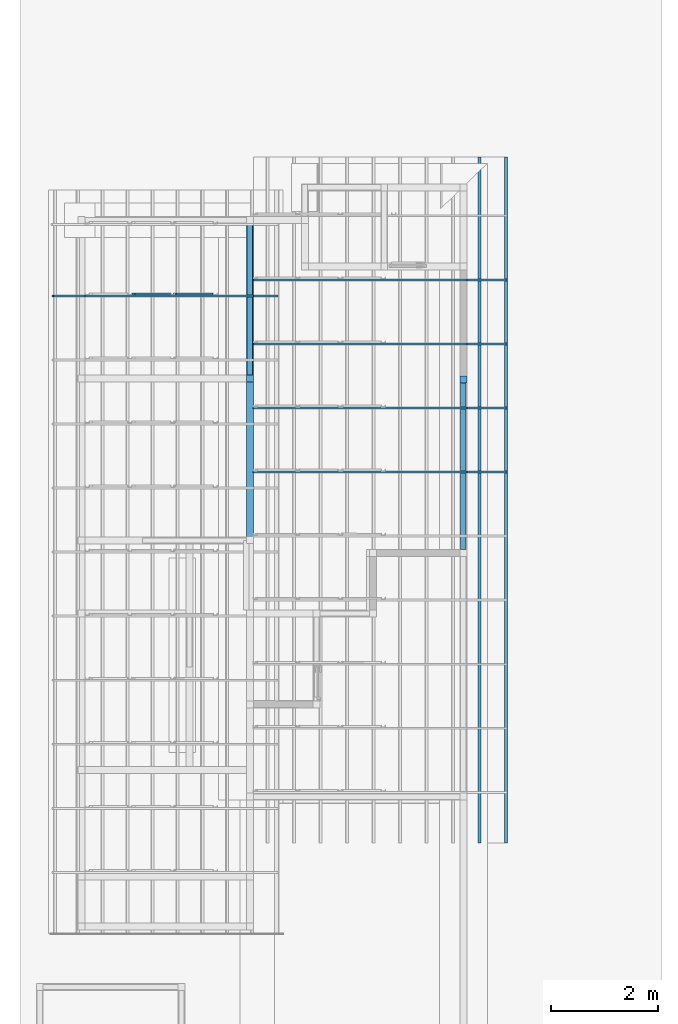
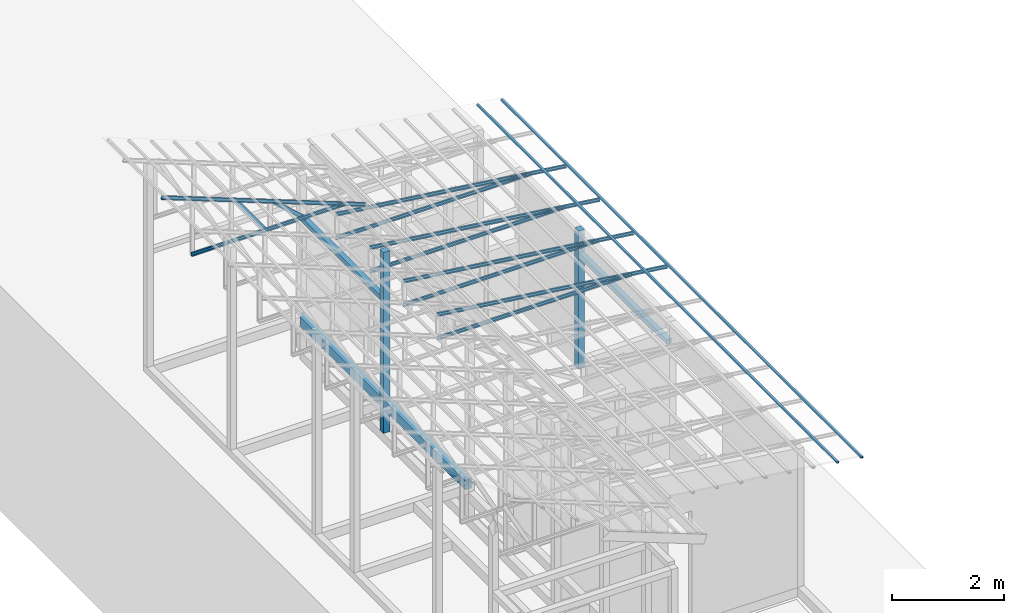
# One storey, part 13 of 22: 14 members, 5 beams, 2 elements without a shape of their own.
"""IFC4 building model written with IfcOpenShell, lengths in millimetres."""

from ifc_helpers import new_model, entity, si_unit, converted_unit, frame, origin_with_axes, origin_2d_with_axis, place, context, subcontext, project, spatial, indexed_curve, rectangle, hollow_rectangle, c_section, outline, extrude, clip, halfspace, material, material_profile, profile_set, profile_usage, type_object, element, aggregate, save


model = new_model("IFC4")

# Units and contexts
model_context = context("Model", 3, precision=1e-05, world=origin_with_axes())
plan_context = context("Plan", 2, precision=1e-05, world=origin_2d_with_axis())
body_context = subcontext(model_context, "Body", "Model", "MODEL_VIEW")
ifc_project = project(units=[si_unit("VOLUMEUNIT", "CUBIC_METRE"), si_unit("LENGTHUNIT", "METRE", prefix="MILLI"), si_unit("AREAUNIT", "SQUARE_METRE"), converted_unit("PLANEANGLEUNIT", "degree", entity("IfcReal", 0.0174532925199433), si_unit("PLANEANGLEUNIT", "RADIAN"), dimensions=[0, 0, 0, 0, 0, 0, 0])], contexts=[model_context, plan_context])

# Site, building, storey
site_placement = place(None, origin_with_axes())
site = spatial("IfcSite", under=ifc_project, at=site_placement)
building_placement = place(site_placement, origin_with_axes())
building = spatial("IfcBuilding", under=site, at=building_placement, Name="2")
storey_placement = place(building_placement, frame((0.0, 0.0, 200.000002980232), z_axis=(0.0, 0.0, 1.0), x_axis=(1.0, 0.0, 0.0)))
storey = spatial("IfcBuildingStorey", under=building, at=storey_placement)

# Beams
ifc_material_1 = material(Name="Concrete")
ifc_material_profile_1 = material_profile(ifc_material_1, outline(indexed_curve([(-65.0, 99.9999923706055), (65.0, 99.9999923706055), (65.0, -99.9999923706055), (-65.0, -99.9999923706055), (-65.0, 99.9999923706055)])))
ifc_profile_set_1 = profile_set([ifc_material_profile_1])
ifc_profile_usage_1 = profile_usage(ifc_profile_set_1, cardinal=3)
beam_type_1 = type_object("IfcBeamType", PredefinedType="BEAM", material=ifc_profile_set_1)
beam_1_placement = place(storey_placement, frame((-3934.99541282654, 11360.2285385132, 535.003766417503), z_axis=(3.89414367418746e-07, 0.999999999999875, 3.13916473260139e-07), x_axis=(-0.999999999999924, 3.89414367418765e-07, -7.40532613008271e-09)))
element("IfcBeam", 1, at=beam_1_placement, inside=storey, type_object=beam_type_1, material=ifc_profile_usage_1, Name="Beam", PredefinedType="BEAM", context=body_context, shape_type="Clipping", body=[
    clip(extrude(outline(indexed_curve([(-65.0, 99.9999923706055), (65.0, 99.9999923706055), (65.0, -99.9999923706055), (-65.0, -99.9999923706055), (-65.0, 99.9999923706055)])), frame((65.0000076293945, 100.0, 0.0), z_axis=(0.0, 0.0, 1.0), x_axis=(1.0, 0.0, 0.0)), (0.0, 0.0, 1.0), 6004.77314872396), halfspace(frame((8.64611209294708e-05, -735.00669002533, 6004.77361679077), z_axis=(0.707110941410065, -2.64117772985628e-07, 0.707102596759796), x_axis=(-3.73516739055016e-07, -0.99999999999993, 0.0)), False)),
])
ifc_material_profile_2 = material_profile(ifc_material_1, rectangle(XDim=130.000015258789, YDim=130.000015258789, kind="CURVE"))
ifc_profile_set_2 = profile_set([ifc_material_profile_2])
ifc_profile_usage_2 = profile_usage(ifc_profile_set_2, cardinal=5)
beam_type_2 = type_object("IfcBeamType", PredefinedType="BEAM", material=ifc_profile_set_2)
beam_2_placement = place(storey_placement, frame((-3999.99594688416, 14330.0046920776, 4.47034838035876e-05), z_axis=(0.0, 0.0, 1.0), x_axis=(1.0, 0.0, 0.0)))
element("IfcBeam", 2, at=beam_2_placement, inside=storey, type_object=beam_type_2, material=ifc_profile_usage_2, Name="Column", PredefinedType="BEAM", context=body_context, shape_type="SweptSolid", body=[
    extrude(rectangle(XDim=130.000015258789, YDim=130.000015258789, kind="CURVE"), origin_with_axes(), (0.0, 0.0, 1.0), 3934.94913943236),
])
ifc_profile_usage_3 = profile_usage(ifc_profile_set_2, cardinal=5)
beam_3_placement = place(storey_placement, frame((0.00166893005371094, 14314.9995803833, 0.00216066837332995), z_axis=(0.0, 0.0, 1.0), x_axis=(1.0, 0.0, 0.0)))
element("IfcBeam", 3, at=beam_3_placement, inside=storey, type_object=beam_type_2, material=ifc_profile_usage_3, Name="Column", PredefinedType="BEAM", context=body_context, shape_type="SweptSolid", body=[
    extrude(rectangle(XDim=130.000015258789, YDim=130.000015258789, kind="CURVE"), origin_with_axes(), (0.0, 0.0, 1.0), 3010.00912205527),
])

# Assembly, members
assembly_1_placement = place(storey_placement, frame((-1561.45393848419, 6600.0657081604, 3019.63977515697), z_axis=(0.0, 0.0, 1.0), x_axis=(1.0, 0.0, 0.0)))
assembly_1 = element("IfcElementAssembly", 4, at=assembly_1_placement, inside=storey, Name="K1")
ifc_material_2 = material(Name="STEEL")
ifc_material_profile_3 = material_profile(ifc_material_2, c_section(Depth=75.0, Width=35.0, WallThickness=1.0, Girth=1.0, kind="CURVE"))
ifc_profile_set_3 = profile_set([ifc_material_profile_3])
ifc_profile_usage_4 = profile_usage(ifc_profile_set_3, cardinal=9)
member_type_1 = type_object("IfcMemberType", Name="C75", PredefinedType="CHORD", material=ifc_profile_set_3)
member_1_placement = place(assembly_1_placement, frame((1634.4433426857, 5998.93236160278, 64.9838447570801), z_axis=(-0.999999999999996, -7.54978941586157e-08, -4.37113882867378e-08), x_axis=(7.54979012640425e-08, -0.999999999999989, -1.2785038450147e-07)))
member_1 = element("IfcMember", 5, at=member_1_placement, type_object=member_type_1, material=ifc_profile_usage_4, Name="Member", context=body_context, shape_type="SweptSolid", body=[
    extrude(c_section(Depth=75.0, Width=35.0, WallThickness=1.0, Girth=1.0, kind="CURVE"), frame((17.5, -37.5, 0.0), z_axis=(0.0, 0.0, 1.0), x_axis=(1.0, 0.0, 0.0)), (0.0, 0.0, 1.0), 4007.95455591631),
])
ifc_profile_usage_5 = profile_usage(ifc_profile_set_3, cardinal=9)
member_2_placement = place(assembly_1_placement, frame((2381.98524713516, 5998.93236160278, -28.5120010375977), z_axis=(-0.991864132670109, -9.11591360127481e-08, 0.127300991050989), x_axis=(7.54979012640425e-08, -0.999999999999989, -1.2785038450147e-07)))
member_2 = element("IfcMember", 6, at=member_2_placement, type_object=member_type_1, material=ifc_profile_usage_5, Name="Member", context=body_context, shape_type="SweptSolid", body=[
    extrude(c_section(Depth=75.0, Width=35.0, WallThickness=1.0, Girth=1.0, kind="CURVE"), frame((17.5, -37.5, 0.0), z_axis=(0.0, 0.0, 1.0), x_axis=(1.0, 0.0, 0.0)), (0.0, 0.0, 1.0), 4790.46084290085),
])
ifc_profile_usage_6 = profile_usage(ifc_profile_set_3, cardinal=9)
member_3_placement = place(assembly_1_placement, frame((1634.4433426857, 7198.93217086792, 64.9838447570801), z_axis=(-0.999999999999996, -7.54978941586157e-08, -4.37113882867378e-08), x_axis=(7.54979012640425e-08, -0.999999999999989, -1.2785038450147e-07)))
member_3 = element("IfcMember", 7, at=member_3_placement, type_object=member_type_1, material=ifc_profile_usage_6, Name="Member", context=body_context, shape_type="SweptSolid", body=[
    extrude(c_section(Depth=75.0, Width=35.0, WallThickness=1.0, Girth=1.0, kind="CURVE"), frame((17.5, -37.5, 0.0), z_axis=(0.0, 0.0, 1.0), x_axis=(1.0, 0.0, 0.0)), (0.0, 0.0, 1.0), 4007.95455591631),
])
ifc_profile_usage_7 = profile_usage(ifc_profile_set_3, cardinal=9)
member_4_placement = place(assembly_1_placement, frame((2381.98524713516, 7198.93217086792, -28.5120010375977), z_axis=(-0.991864132670109, -9.11591360127481e-08, 0.127300991050989), x_axis=(7.54979012640425e-08, -0.999999999999989, -1.2785038450147e-07)))
member_4 = element("IfcMember", 8, at=member_4_placement, type_object=member_type_1, material=ifc_profile_usage_7, Name="Member", context=body_context, shape_type="SweptSolid", body=[
    extrude(c_section(Depth=75.0, Width=35.0, WallThickness=1.0, Girth=1.0, kind="CURVE"), frame((17.5, -37.5, 0.0), z_axis=(0.0, 0.0, 1.0), x_axis=(1.0, 0.0, 0.0)), (0.0, 0.0, 1.0), 4790.46084290085),
])
ifc_profile_usage_8 = profile_usage(ifc_profile_set_3, cardinal=9)
member_5_placement = place(assembly_1_placement, frame((1634.4433426857, 8398.93198013306, 64.9838447570801), z_axis=(-0.999999999999996, -7.54978941586157e-08, -4.37113882867378e-08), x_axis=(7.54979012640425e-08, -0.999999999999989, -1.2785038450147e-07)))
member_5 = element("IfcMember", 9, at=member_5_placement, type_object=member_type_1, material=ifc_profile_usage_8, Name="Member", context=body_context, shape_type="SweptSolid", body=[
    extrude(c_section(Depth=75.0, Width=35.0, WallThickness=1.0, Girth=1.0, kind="CURVE"), frame((17.5, -37.5, 0.0), z_axis=(0.0, 0.0, 1.0), x_axis=(1.0, 0.0, 0.0)), (0.0, 0.0, 1.0), 4007.95455591631),
])
ifc_profile_usage_9 = profile_usage(ifc_profile_set_3, cardinal=9)
member_6_placement = place(assembly_1_placement, frame((2381.98524713516, 8398.93198013306, -28.5120010375977), z_axis=(-0.991864132670109, -9.11591360127481e-08, 0.127300991050989), x_axis=(7.54979012640425e-08, -0.999999999999989, -1.2785038450147e-07)))
member_6 = element("IfcMember", 10, at=member_6_placement, type_object=member_type_1, material=ifc_profile_usage_9, Name="Member", context=body_context, shape_type="SweptSolid", body=[
    extrude(c_section(Depth=75.0, Width=35.0, WallThickness=1.0, Girth=1.0, kind="CURVE"), frame((17.5, -37.5, 0.0), z_axis=(0.0, 0.0, 1.0), x_axis=(1.0, 0.0, 0.0)), (0.0, 0.0, 1.0), 4790.46084290085),
])
ifc_profile_usage_10 = profile_usage(ifc_profile_set_3, cardinal=9)
member_7_placement = place(assembly_1_placement, frame((1634.4433426857, 9598.93178939819, 64.9838447570801), z_axis=(-0.999999999999996, -7.54978941586157e-08, -4.37113882867378e-08), x_axis=(7.54979012640425e-08, -0.999999999999989, -1.2785038450147e-07)))
member_7 = element("IfcMember", 11, at=member_7_placement, type_object=member_type_1, material=ifc_profile_usage_10, Name="Member", context=body_context, shape_type="SweptSolid", body=[
    extrude(c_section(Depth=75.0, Width=35.0, WallThickness=1.0, Girth=1.0, kind="CURVE"), frame((17.5, -37.5, 0.0), z_axis=(0.0, 0.0, 1.0), x_axis=(1.0, 0.0, 0.0)), (0.0, 0.0, 1.0), 4007.95455591631),
])
ifc_profile_usage_11 = profile_usage(ifc_profile_set_3, cardinal=9)
member_8_placement = place(assembly_1_placement, frame((2381.98524713516, 9598.93178939819, -28.5120010375977), z_axis=(-0.991864132670109, -9.11591360127481e-08, 0.127300991050989), x_axis=(7.54979012640425e-08, -0.999999999999989, -1.2785038450147e-07)))
member_8 = element("IfcMember", 12, at=member_8_placement, type_object=member_type_1, material=ifc_profile_usage_11, Name="Member", context=body_context, shape_type="SweptSolid", body=[
    extrude(c_section(Depth=75.0, Width=35.0, WallThickness=1.0, Girth=1.0, kind="CURVE"), frame((17.5, -37.5, 0.0), z_axis=(0.0, 0.0, 1.0), x_axis=(1.0, 0.0, 0.0)), (0.0, 0.0, 1.0), 4790.46084290085),
])
aggregate(assembly_1, [member_1, member_2, member_3, member_4, member_5, member_6, member_7, member_8])

assembly_2_placement = place(storey_placement, frame((-3938.51041793823, 5099.00283813477, 3935.3459328413), z_axis=(0.0, 0.0, 1.0), x_axis=(1.0, 0.0, 0.0)))
assembly_2 = element("IfcElementAssembly", 13, at=assembly_2_placement, inside=storey, Name="2")
ifc_profile_usage_12 = profile_usage(ifc_profile_set_3, cardinal=7)
member_9_placement = place(assembly_2_placement, frame((-1445.26290893555, 10835.9594345093, 624.074935913086), z_axis=(0.745142107017777, -0.00102660805644996, -0.66690493057482), x_axis=(0.00137753843534741, 0.999999051193456, -2.17762747561669e-07)))
member_9 = element("IfcMember", 14, at=member_9_placement, type_object=member_type_1, material=ifc_profile_usage_12, Name="Member", context=body_context, shape_type="SweptSolid", body=[
    extrude(c_section(Depth=75.0, Width=35.0, WallThickness=1.0, Girth=1.0, kind="CURVE"), frame((-17.5, -37.5, 0.0), z_axis=(0.0, 0.0, 1.0), x_axis=(1.0, 0.0, 0.0)), (0.0, 0.0, 1.0), 937.808496265298),
])
ifc_profile_usage_13 = profile_usage(ifc_profile_set_3, cardinal=1)
member_10_placement = place(assembly_2_placement, frame((3.51285934448242, 10764.9984359741, -1.35517120361328), z_axis=(-0.999999999999812, -4.33125762810878e-07, 4.33125762810878e-07), x_axis=(4.33125762810919e-07, -0.999999999999906, -1.13742348872837e-13)))
member_10 = element("IfcMember", 15, at=member_10_placement, type_object=member_type_1, material=ifc_profile_usage_13, Name="Member", context=body_context, shape_type="SweptSolid", body=[
    extrude(c_section(Depth=75.0, Width=35.0, WallThickness=1.0, Girth=1.0, kind="CURVE"), frame((-17.5, 37.5, 0.0), z_axis=(0.0, 0.0, 1.0), x_axis=(1.0, 0.0, 0.0)), (0.0, 0.0, 1.0), 3150.02386296032),
])
ifc_profile_usage_14 = profile_usage(ifc_profile_set_3, cardinal=1)
member_11_placement = place(assembly_2_placement, frame((438.234329223633, 10764.9993896484, -169.034004211426), z_axis=(-0.933001152035968, -8.32115964913738e-07, 0.359873380925658), x_axis=(9.09962921013707e-07, -0.999999999999585, 4.6906695416718e-08)))
member_11 = element("IfcMember", 16, at=member_11_placement, type_object=member_type_1, material=ifc_profile_usage_14, Name="Member", context=body_context, shape_type="SweptSolid", body=[
    extrude(c_section(Depth=75.0, Width=35.0, WallThickness=1.0, Girth=1.0, kind="CURVE"), frame((-17.5, 37.5, 0.0), z_axis=(0.0, 0.0, 1.0), x_axis=(1.0, 0.0, 0.0)), (0.0, 0.0, 1.0), 4510.0754953159),
])
ifc_profile_usage_15 = profile_usage(ifc_profile_set_3, cardinal=3)
member_12_placement = place(assembly_2_placement, frame((-2271.51107788086, 10799.9982833862, 894.618034362793), z_axis=(0.578723368640778, -7.49756619914683e-07, -0.815523919078103), x_axis=(1.02917226740772e-06, 0.999999999999453, -1.89020340712783e-07)))
member_12 = element("IfcMember", 17, at=member_12_placement, type_object=member_type_1, material=ifc_profile_usage_15, Name="Member", context=body_context, shape_type="SweptSolid", body=[
    extrude(c_section(Depth=75.0, Width=35.0, WallThickness=1.0, Girth=1.0, kind="CURVE"), frame((17.5, 37.5, 0.0), z_axis=(0.0, 0.0, 1.0), x_axis=(1.0, 0.0, 0.0)), (0.0, 0.0, 1.0), 1142.30360336039),
])
aggregate(assembly_2, [member_9, member_10, member_11, member_12])

# Members
ifc_material_profile_4 = material_profile(ifc_material_2, hollow_rectangle(XDim=50.0, YDim=33.0, WallThickness=1.0, InnerFilletRadius=1.0, OuterFilletRadius=0.0, kind="CURVE"))
ifc_profile_set_4 = profile_set([ifc_material_profile_4])
ifc_profile_usage_16 = profile_usage(ifc_profile_set_4, cardinal=3)
member_type_2 = type_object("IfcMemberType", PredefinedType="CHORD", material=ifc_profile_set_4)
member_13_placement = place(storey_placement, frame((820.53130865097, 5634.99975204468, 2991.12777411938), z_axis=(5.55417489778164e-09, 0.999999999999999, 4.33570832569785e-08), x_axis=(-0.99189443015292, 0.0, 0.127064705688141)))
element("IfcMember", 18, at=member_13_placement, inside=storey, type_object=member_type_2, material=ifc_profile_usage_16, Name="Member", context=body_context, shape_type="SweptSolid", body=[
    extrude(hollow_rectangle(XDim=50.0, YDim=33.0, WallThickness=1.0, InnerFilletRadius=1.0, OuterFilletRadius=0.0, kind="CURVE"), frame((25.0, 16.5, 0.0), z_axis=(0.0, 0.0, 1.0), x_axis=(1.0, 0.0, 0.0)), (0.0, 0.0, 1.0), 12845.0009370286),
])
ifc_profile_usage_17 = profile_usage(ifc_profile_set_4, cardinal=3)
member_14_placement = place(storey_placement, frame((324.584096670151, 5634.99975204468, 3054.66012656689), z_axis=(5.55417489778164e-09, 0.999999999999999, 4.33570832569785e-08), x_axis=(-0.99189443015292, 0.0, 0.127064705688141)))
element("IfcMember", 19, at=member_14_placement, inside=storey, type_object=member_type_2, material=ifc_profile_usage_17, Name="Member", context=body_context, shape_type="SweptSolid", body=[
    extrude(hollow_rectangle(XDim=50.0, YDim=33.0, WallThickness=1.0, InnerFilletRadius=1.0, OuterFilletRadius=0.0, kind="CURVE"), frame((25.0, 16.5, 0.0), z_axis=(0.0, 0.0, 1.0), x_axis=(1.0, 0.0, 0.0)), (0.0, 0.0, 1.0), 12845.0009370286),
])

# Beams
ifc_material_profile_5 = material_profile(ifc_material_1, rectangle(XDim=100.0, YDim=100.0))
ifc_profile_set_5 = profile_set([ifc_material_profile_5])
ifc_profile_usage_18 = profile_usage(ifc_profile_set_5, cardinal=2)
beam_type_3 = type_object("IfcBeamType", PredefinedType="BEAM", material=ifc_profile_set_5)
beam_4_placement = place(storey_placement, frame((-3999.99737739563, 14395.0042724609, 2815.00463187695), z_axis=(3.89414367418746e-07, 0.999999999999875, 3.13916473260139e-07), x_axis=(-0.999999999999924, 3.89414367418765e-07, -7.40532613008271e-09)))
element("IfcBeam", 20, at=beam_4_placement, inside=storey, type_object=beam_type_3, material=ifc_profile_usage_18, Name="Beam", PredefinedType="BEAM", context=body_context, shape_type="SweptSolid", body=[
    extrude(rectangle(XDim=100.0, YDim=100.0), frame((0.0, 50.0, 0.0), z_axis=(0.0, 0.0, 1.0), x_axis=(1.0, 0.0, 0.0)), (0.0, 0.0, 1.0), 2854.99762994338),
])
ifc_profile_usage_19 = profile_usage(ifc_profile_set_5, cardinal=2)
beam_5_placement = place(storey_placement, frame((0.000991287265605933, 11129.9991607666, 2430.00130355358), z_axis=(1.50995802528082e-07, 0.99999999999997, 1.94707183709391e-07), x_axis=(-0.999999999999989, 1.50995802528085e-07, 3.24144183716509e-11)))
element("IfcBeam", 21, at=beam_5_placement, inside=storey, type_object=beam_type_3, material=ifc_profile_usage_19, Name="Beam", PredefinedType="BEAM", context=body_context, shape_type="SweptSolid", body=[
    extrude(rectangle(XDim=100.0, YDim=100.0), frame((0.0, 50.0, 0.0), z_axis=(0.0, 0.0, 1.0), x_axis=(1.0, 0.0, 0.0)), (0.0, 0.0, 1.0), 3120.00088422726),
])

save(model, "model.ifc")
